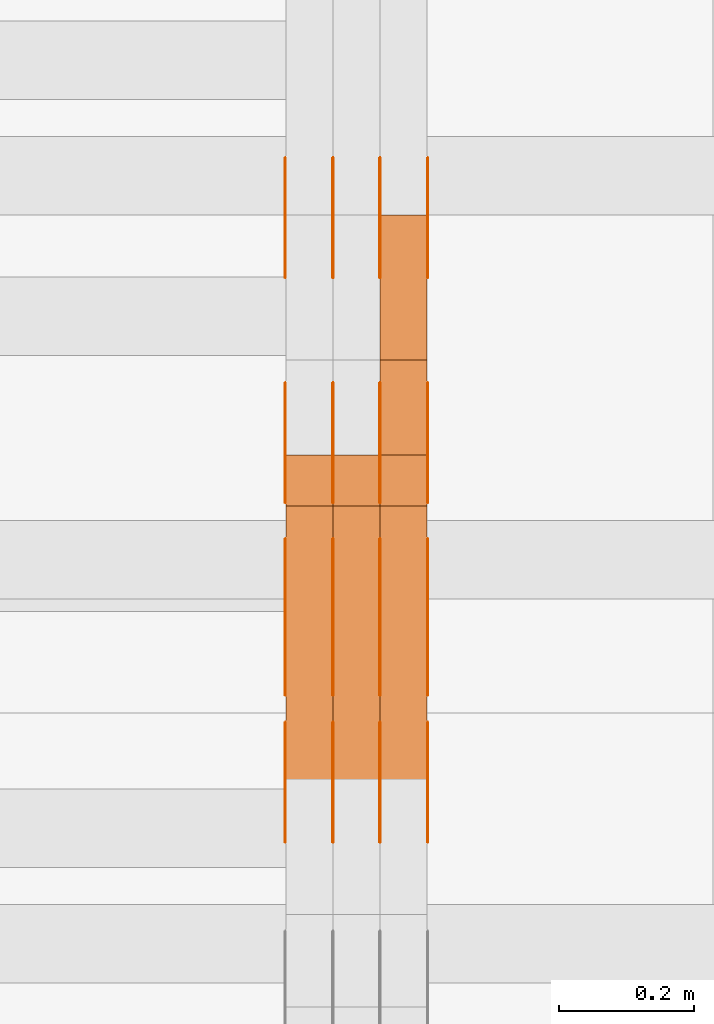
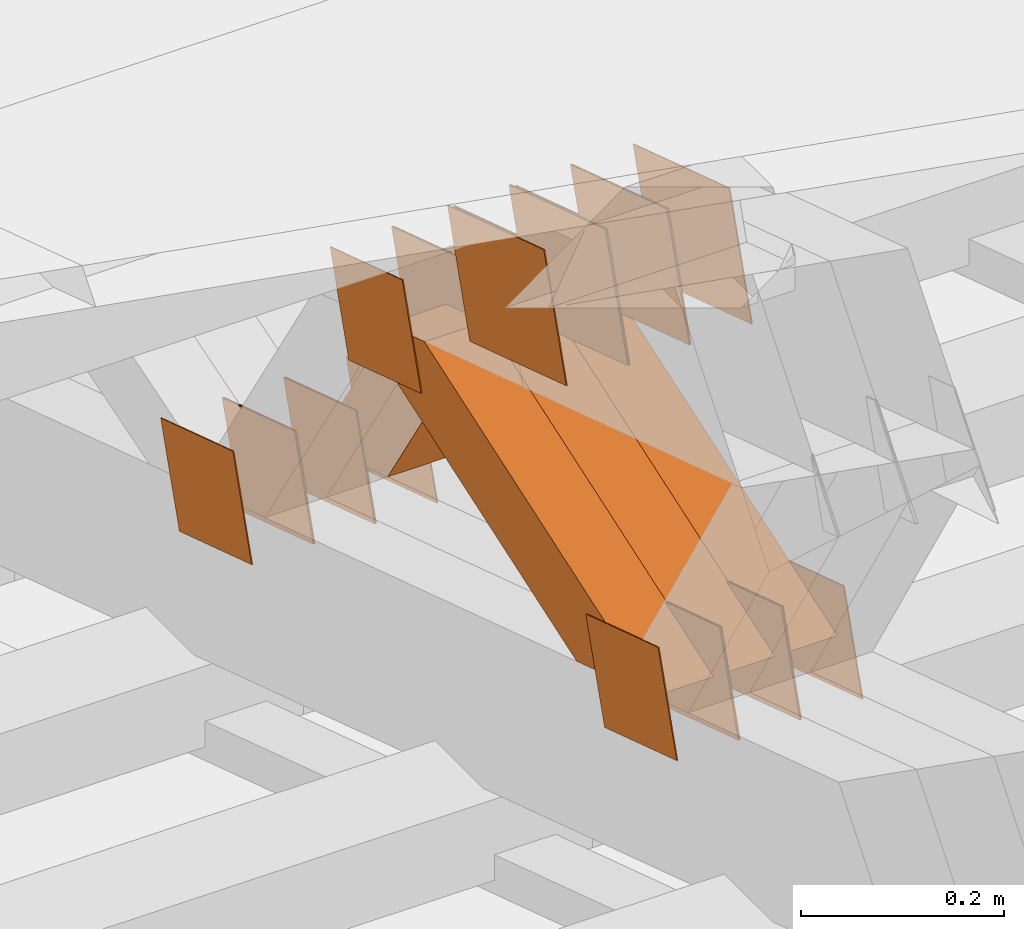
# One storey, part 173 of 385: 28 proxies.
"""IFC2X3 building model written with IfcOpenShell, lengths in millimetres."""

from ifc_helpers import new_model, entity, si_unit, converted_unit, derived_unit, direction, frame, origin, place, context, subcontext, project, spatial, polyline, outline, extrude, source, transform, mapped, material, type_object, type_shapes, element, save


model = new_model("IFC2X3")

# Units and contexts
model_context = context("Model", 3, precision=0.01, world=origin(), true_north=direction((6.12303176911189e-17, 1.0)))
body_context = subcontext(model_context, "Body", "Model", "MODEL_VIEW")
ifc_project = project(units=[si_unit("LENGTHUNIT", "METRE", prefix="MILLI"), si_unit("AREAUNIT", "SQUARE_METRE"), si_unit("VOLUMEUNIT", "CUBIC_METRE"), converted_unit("PLANEANGLEUNIT", "DEGREE", entity("IfcRatioMeasure", 0.0174532925199433), si_unit("PLANEANGLEUNIT", "RADIAN"), dimensions=[0, 0, 0, 0, 0, 0, 0]), si_unit("MASSUNIT", "GRAM", prefix="KILO"), derived_unit("MASSDENSITYUNIT", [(si_unit("MASSUNIT", "GRAM", prefix="KILO"), 1), (si_unit("LENGTHUNIT", "METRE"), -3)]), si_unit("TIMEUNIT", "SECOND"), si_unit("FREQUENCYUNIT", "HERTZ"), si_unit("THERMODYNAMICTEMPERATUREUNIT", "DEGREE_CELSIUS"), derived_unit("THERMALTRANSMITTANCEUNIT", [(si_unit("MASSUNIT", "GRAM", prefix="KILO"), 1), (si_unit("THERMODYNAMICTEMPERATUREUNIT", "KELVIN"), -1), (si_unit("TIMEUNIT", "SECOND"), -3)]), derived_unit("VOLUMETRICFLOWRATEUNIT", [(si_unit("LENGTHUNIT", "METRE"), 3), (si_unit("TIMEUNIT", "SECOND"), -1)]), si_unit("ELECTRICCURRENTUNIT", "AMPERE"), si_unit("ELECTRICVOLTAGEUNIT", "VOLT"), si_unit("POWERUNIT", "WATT"), si_unit("FORCEUNIT", "NEWTON", prefix="KILO"), si_unit("ILLUMINANCEUNIT", "LUX"), si_unit("LUMINOUSFLUXUNIT", "LUMEN"), si_unit("LUMINOUSINTENSITYUNIT", "CANDELA"), derived_unit("USERDEFINED", [(si_unit("MASSUNIT", "GRAM", prefix="KILO"), -1), (si_unit("LENGTHUNIT", "METRE"), -2), (si_unit("TIMEUNIT", "SECOND"), 3), (si_unit("LUMINOUSFLUXUNIT", "LUMEN"), 1)]), derived_unit("LINEARVELOCITYUNIT", [(si_unit("LENGTHUNIT", "METRE"), 1), (si_unit("TIMEUNIT", "SECOND"), -1)]), si_unit("PRESSUREUNIT", "PASCAL"), derived_unit("USERDEFINED", [(si_unit("LENGTHUNIT", "METRE"), -2), (si_unit("MASSUNIT", "GRAM", prefix="KILO"), 1), (si_unit("TIMEUNIT", "SECOND"), -2)])], contexts=[model_context])

# Site, building, storey
site_placement = place(None, origin())
site = spatial("IfcSite", under=ifc_project, at=site_placement, CompositionType="ELEMENT")
building_placement = place(site_placement, origin())
building = spatial("IfcBuilding", under=site, at=building_placement, CompositionType="ELEMENT")
storey_placement = place(building_placement, origin())
storey = spatial("IfcBuildingStorey", under=building, at=storey_placement, Name="Default", CompositionType="ELEMENT", Elevation=0.0)

# Proxies
ifc_material_1 = material(Name="IfcSurfaceStyle #74490")
building_element_proxy_type_1 = type_object("IfcBuildingElementProxyType", PredefinedType="NOTDEFINED", material=ifc_material_1)
shared_shape_1 = source(origin(), body_context, "Body", "SweptSolid", [
    extrude(outline(polyline([(-74.9998605591059, -59.9999264677526), (74.999875428623, -59.9999264677526), (74.9998605591068, 59.9999264677526), (-74.9998754286239, 59.9999264677526), (-74.9998605591059, -59.9999264677526)])), frame((75.0000889884782, 60.0000460315623, 0.0), z_axis=(0.0, 0.0, 1.0), x_axis=(-1.0, 0.0, 0.0)), (0.0, 0.0, 1.0), 1.3),
])
type_shapes(building_element_proxy_type_1, [shared_shape_1])
proxy_1_placement = place(building_placement, frame((3386.29999999999, 20621.9679769682, 2241.76551219004), z_axis=(-1.0, 0.0, 0.0), x_axis=(0.0, -0.951056516295154, 0.309016994374948)))
element("IfcBuildingElementProxy", 1, at=proxy_1_placement, inside=storey, type_object=building_element_proxy_type_1, material=ifc_material_1, context=body_context, shape_type="MappedRepresentation", body=[
    mapped(shared_shape_1, transform((0.0, 0.0, 0.0), scale=1.0)),
])
ifc_material_2 = material(Name="IfcSurfaceStyle #74433")
building_element_proxy_type_2 = type_object("IfcBuildingElementProxyType", PredefinedType="NOTDEFINED", material=ifc_material_2)
shared_shape_2 = source(origin(), body_context, "Body", "SweptSolid", [
    extrude(outline(polyline([(-74.9998605591059, -59.9999264677526), (74.999875428623, -59.9999264677526), (74.9998605591068, 59.9999264677526), (-74.9998754286239, 59.9999264677526), (-74.9998605591059, -59.9999264677526)])), frame((75.0000889884782, 60.0000460315623, 0.0), z_axis=(0.0, 0.0, 1.0), x_axis=(-1.0, 0.0, 0.0)), (0.0, 0.0, 1.0), 1.3),
])
type_shapes(building_element_proxy_type_2, [shared_shape_2])
proxy_2_placement = place(building_placement, frame((3315.0, 20621.9679769682, 2241.76551219004), z_axis=(-1.0, 0.0, 0.0), x_axis=(0.0, -0.951056516295154, 0.309016994374948)))
element("IfcBuildingElementProxy", 2, at=proxy_2_placement, inside=storey, type_object=building_element_proxy_type_2, material=ifc_material_2, context=body_context, shape_type="MappedRepresentation", body=[
    mapped(shared_shape_2, transform((0.0, 0.0, 0.0), scale=1.0)),
])
ifc_material_3 = material(Name="IfcSurfaceStyle #74376")
building_element_proxy_type_3 = type_object("IfcBuildingElementProxyType", PredefinedType="NOTDEFINED", material=ifc_material_3)
shared_shape_3 = source(origin(), body_context, "Body", "SweptSolid", [
    extrude(outline(polyline([(-74.9998605591059, -59.9999264677526), (74.999875428623, -59.9999264677526), (74.9998605591068, 59.9999264677526), (-74.9998754286239, 59.9999264677526), (-74.9998605591059, -59.9999264677526)])), frame((75.0000889884782, 60.0000460315623, 0.0), z_axis=(0.0, 0.0, 1.0), x_axis=(-1.0, 0.0, 0.0)), (0.0, 0.0, 1.0), 1.3),
])
type_shapes(building_element_proxy_type_3, [shared_shape_3])
proxy_3_placement = place(building_placement, frame((3316.29999999999, 20621.9679769682, 2241.76551219004), z_axis=(-1.0, 0.0, 0.0), x_axis=(0.0, -0.951056516295154, 0.309016994374948)))
element("IfcBuildingElementProxy", 3, at=proxy_3_placement, inside=storey, type_object=building_element_proxy_type_3, material=ifc_material_3, context=body_context, shape_type="MappedRepresentation", body=[
    mapped(shared_shape_3, transform((0.0, 0.0, 0.0), scale=1.0)),
])
ifc_material_4 = material(Name="IfcSurfaceStyle #74319")
building_element_proxy_type_4 = type_object("IfcBuildingElementProxyType", PredefinedType="NOTDEFINED", material=ifc_material_4)
shared_shape_4 = source(origin(), body_context, "Body", "SweptSolid", [
    extrude(outline(polyline([(-74.9998605591059, -59.9999264677526), (74.999875428623, -59.9999264677526), (74.9998605591068, 59.9999264677526), (-74.9998754286239, 59.9999264677526), (-74.9998605591059, -59.9999264677526)])), frame((75.0000889884782, 60.0000460315623, 0.0), z_axis=(0.0, 0.0, 1.0), x_axis=(-1.0, 0.0, 0.0)), (0.0, 0.0, 1.0), 1.29999999999999),
])
type_shapes(building_element_proxy_type_4, [shared_shape_4])
proxy_4_placement = place(building_placement, frame((3245.0, 20621.9679769682, 2241.76551219004), z_axis=(-1.0, 0.0, 0.0), x_axis=(0.0, -0.951056516295154, 0.309016994374948)))
element("IfcBuildingElementProxy", 4, at=proxy_4_placement, inside=storey, type_object=building_element_proxy_type_4, material=ifc_material_4, context=body_context, shape_type="MappedRepresentation", body=[
    mapped(shared_shape_4, transform((0.0, 0.0, 0.0), scale=1.0)),
])
ifc_material_5 = material(Name="IfcSurfaceStyle #74262")
building_element_proxy_type_5 = type_object("IfcBuildingElementProxyType", PredefinedType="NOTDEFINED", material=ifc_material_5)
shared_shape_5 = source(origin(), body_context, "Body", "SweptSolid", [
    extrude(outline(polyline([(-74.9998605591059, -59.9999264677526), (74.999875428623, -59.9999264677526), (74.9998605591068, 59.9999264677526), (-74.9998754286239, 59.9999264677526), (-74.9998605591059, -59.9999264677526)])), frame((75.0000889884782, 60.0000460315623, 0.0), z_axis=(0.0, 0.0, 1.0), x_axis=(-1.0, 0.0, 0.0)), (0.0, 0.0, 1.0), 1.29999999999999),
])
type_shapes(building_element_proxy_type_5, [shared_shape_5])
proxy_5_placement = place(building_placement, frame((3246.29999999999, 20621.9679769682, 2241.76551219004), z_axis=(-1.0, 0.0, 0.0), x_axis=(0.0, -0.951056516295154, 0.309016994374948)))
element("IfcBuildingElementProxy", 5, at=proxy_5_placement, inside=storey, type_object=building_element_proxy_type_5, material=ifc_material_5, context=body_context, shape_type="MappedRepresentation", body=[
    mapped(shared_shape_5, transform((0.0, 0.0, 0.0), scale=1.0)),
])
ifc_material_6 = material(Name="IfcSurfaceStyle #74205")
building_element_proxy_type_6 = type_object("IfcBuildingElementProxyType", PredefinedType="NOTDEFINED", material=ifc_material_6)
shared_shape_6 = source(origin(), body_context, "Body", "SweptSolid", [
    extrude(outline(polyline([(-74.9998605591059, -59.9999264677526), (74.999875428623, -59.9999264677526), (74.9998605591068, 59.9999264677526), (-74.9998754286239, 59.9999264677526), (-74.9998605591059, -59.9999264677526)])), frame((75.0000889884782, 60.0000460315623, 0.0), z_axis=(0.0, 0.0, 1.0), x_axis=(-1.0, 0.0, 0.0)), (0.0, 0.0, 1.0), 1.29999999999999),
])
type_shapes(building_element_proxy_type_6, [shared_shape_6])
proxy_6_placement = place(building_placement, frame((3175.0, 20621.9679769682, 2241.76551219004), z_axis=(-1.0, 0.0, 0.0), x_axis=(0.0, -0.951056516295154, 0.309016994374948)))
element("IfcBuildingElementProxy", 6, at=proxy_6_placement, inside=storey, type_object=building_element_proxy_type_6, material=ifc_material_6, context=body_context, shape_type="MappedRepresentation", body=[
    mapped(shared_shape_6, transform((0.0, 0.0, 0.0), scale=1.0)),
])
ifc_material_7 = material(Name="IfcSurfaceStyle #72780")
building_element_proxy_type_7 = type_object("IfcBuildingElementProxyType", PredefinedType="NOTDEFINED", material=ifc_material_7)
shared_shape_7 = source(origin(), body_context, "Body", "SweptSolid", [
    extrude(outline(polyline([(-100.000260677523, -72.0000050220369), (100.000341220114, -72.0000050220369), (99.9997962944585, 72.0000050220369), (-99.9998768370492, 72.0000050220369), (-100.000260677523, -72.0000050220369)])), frame((100.000341220114, 72.0001826453454, 0.0), z_axis=(0.0, 0.0, 1.0), x_axis=(-1.0, 0.0, 0.0)), (0.0, 0.0, 1.0), 1.3),
])
type_shapes(building_element_proxy_type_7, [shared_shape_7])
proxy_7_placement = place(building_placement, frame((3386.29999999999, 20382.8706354426, 2409.35285895246), z_axis=(-1.0, 0.0, 0.0), x_axis=(0.0, -0.951056516295154, 0.309016994374948)))
element("IfcBuildingElementProxy", 7, at=proxy_7_placement, inside=storey, type_object=building_element_proxy_type_7, material=ifc_material_7, context=body_context, shape_type="MappedRepresentation", body=[
    mapped(shared_shape_7, transform((0.0, 0.0, 0.0), scale=1.0)),
])
ifc_material_8 = material(Name="IfcSurfaceStyle #72723")
building_element_proxy_type_8 = type_object("IfcBuildingElementProxyType", PredefinedType="NOTDEFINED", material=ifc_material_8)
shared_shape_8 = source(origin(), body_context, "Body", "SweptSolid", [
    extrude(outline(polyline([(-100.000260677523, -72.0000050220369), (100.000341220114, -72.0000050220369), (99.9997962944585, 72.0000050220369), (-99.9998768370492, 72.0000050220369), (-100.000260677523, -72.0000050220369)])), frame((100.000341220114, 72.0001826453454, 0.0), z_axis=(0.0, 0.0, 1.0), x_axis=(-1.0, 0.0, 0.0)), (0.0, 0.0, 1.0), 1.3),
])
type_shapes(building_element_proxy_type_8, [shared_shape_8])
proxy_8_placement = place(building_placement, frame((3315.0, 20382.8706354426, 2409.35285895246), z_axis=(-1.0, 0.0, 0.0), x_axis=(0.0, -0.951056516295154, 0.309016994374948)))
element("IfcBuildingElementProxy", 8, at=proxy_8_placement, inside=storey, type_object=building_element_proxy_type_8, material=ifc_material_8, context=body_context, shape_type="MappedRepresentation", body=[
    mapped(shared_shape_8, transform((0.0, 0.0, 0.0), scale=1.0)),
])
ifc_material_9 = material(Name="IfcSurfaceStyle #72666")
building_element_proxy_type_9 = type_object("IfcBuildingElementProxyType", PredefinedType="NOTDEFINED", material=ifc_material_9)
shared_shape_9 = source(origin(), body_context, "Body", "SweptSolid", [
    extrude(outline(polyline([(-100.000260677523, -72.0000050220369), (100.000341220114, -72.0000050220369), (99.9997962944585, 72.0000050220369), (-99.9998768370492, 72.0000050220369), (-100.000260677523, -72.0000050220369)])), frame((100.000341220114, 72.0001826453454, 0.0), z_axis=(0.0, 0.0, 1.0), x_axis=(-1.0, 0.0, 0.0)), (0.0, 0.0, 1.0), 1.3),
])
type_shapes(building_element_proxy_type_9, [shared_shape_9])
proxy_9_placement = place(building_placement, frame((3316.29999999999, 20382.8706354426, 2409.35285895246), z_axis=(-1.0, 0.0, 0.0), x_axis=(0.0, -0.951056516295154, 0.309016994374948)))
element("IfcBuildingElementProxy", 9, at=proxy_9_placement, inside=storey, type_object=building_element_proxy_type_9, material=ifc_material_9, context=body_context, shape_type="MappedRepresentation", body=[
    mapped(shared_shape_9, transform((0.0, 0.0, 0.0), scale=1.0)),
])
ifc_material_10 = material(Name="IfcSurfaceStyle #72609")
building_element_proxy_type_10 = type_object("IfcBuildingElementProxyType", PredefinedType="NOTDEFINED", material=ifc_material_10)
shared_shape_10 = source(origin(), body_context, "Body", "SweptSolid", [
    extrude(outline(polyline([(-100.000260677523, -72.0000050220369), (100.000341220114, -72.0000050220369), (99.9997962944585, 72.0000050220369), (-99.9998768370492, 72.0000050220369), (-100.000260677523, -72.0000050220369)])), frame((100.000341220114, 72.0001826453454, 0.0), z_axis=(0.0, 0.0, 1.0), x_axis=(-1.0, 0.0, 0.0)), (0.0, 0.0, 1.0), 1.29999999999998),
])
type_shapes(building_element_proxy_type_10, [shared_shape_10])
proxy_10_placement = place(building_placement, frame((3245.0, 20382.8706354426, 2409.35285895246), z_axis=(-1.0, 0.0, 0.0), x_axis=(0.0, -0.951056516295154, 0.309016994374948)))
element("IfcBuildingElementProxy", 10, at=proxy_10_placement, inside=storey, type_object=building_element_proxy_type_10, material=ifc_material_10, context=body_context, shape_type="MappedRepresentation", body=[
    mapped(shared_shape_10, transform((0.0, 0.0, 0.0), scale=1.0)),
])
ifc_material_11 = material(Name="IfcSurfaceStyle #72552")
building_element_proxy_type_11 = type_object("IfcBuildingElementProxyType", PredefinedType="NOTDEFINED", material=ifc_material_11)
shared_shape_11 = source(origin(), body_context, "Body", "SweptSolid", [
    extrude(outline(polyline([(-100.000260677523, -72.0000050220369), (100.000341220114, -72.0000050220369), (99.9997962944585, 72.0000050220369), (-99.9998768370492, 72.0000050220369), (-100.000260677523, -72.0000050220369)])), frame((100.000341220114, 72.0001826453454, 0.0), z_axis=(0.0, 0.0, 1.0), x_axis=(-1.0, 0.0, 0.0)), (0.0, 0.0, 1.0), 1.29999999999998),
])
type_shapes(building_element_proxy_type_11, [shared_shape_11])
proxy_11_placement = place(building_placement, frame((3246.29999999999, 20382.8706354426, 2409.35285895246), z_axis=(-1.0, 0.0, 0.0), x_axis=(0.0, -0.951056516295154, 0.309016994374948)))
element("IfcBuildingElementProxy", 11, at=proxy_11_placement, inside=storey, type_object=building_element_proxy_type_11, material=ifc_material_11, context=body_context, shape_type="MappedRepresentation", body=[
    mapped(shared_shape_11, transform((0.0, 0.0, 0.0), scale=1.0)),
])
ifc_material_12 = material(Name="IfcSurfaceStyle #72495")
building_element_proxy_type_12 = type_object("IfcBuildingElementProxyType", PredefinedType="NOTDEFINED", material=ifc_material_12)
shared_shape_12 = source(origin(), body_context, "Body", "SweptSolid", [
    extrude(outline(polyline([(-100.000260677523, -72.0000050220369), (100.000341220114, -72.0000050220369), (99.9997962944585, 72.0000050220369), (-99.9998768370492, 72.0000050220369), (-100.000260677523, -72.0000050220369)])), frame((100.000341220114, 72.0001826453454, 0.0), z_axis=(0.0, 0.0, 1.0), x_axis=(-1.0, 0.0, 0.0)), (0.0, 0.0, 1.0), 1.29999999999999),
])
type_shapes(building_element_proxy_type_12, [shared_shape_12])
proxy_12_placement = place(building_placement, frame((3175.0, 20382.8706354426, 2409.35285895246), z_axis=(-1.0, 0.0, 0.0), x_axis=(0.0, -0.951056516295154, 0.309016994374948)))
element("IfcBuildingElementProxy", 12, at=proxy_12_placement, inside=storey, type_object=building_element_proxy_type_12, material=ifc_material_12, context=body_context, shape_type="MappedRepresentation", body=[
    mapped(shared_shape_12, transform((0.0, 0.0, 0.0), scale=1.0)),
])
ifc_material_13 = material(Name="IfcSurfaceStyle #66282")
building_element_proxy_type_13 = type_object("IfcBuildingElementProxyType", PredefinedType="NOTDEFINED", material=ifc_material_13)
shared_shape_13 = source(origin(), body_context, "Body", "SweptSolid", [
    extrude(outline(polyline([(-74.9998605591118, -59.9999264677598), (74.9998754286171, -59.9999264677598), (74.9998605591136, 59.9999264677598), (-74.9998754286189, 59.9999264677598), (-74.9998605591118, -59.9999264677598)])), frame((75.0000347664736, 60.0000016373434, 0.0), z_axis=(0.0, 0.0, 1.0), x_axis=(-1.0, 0.0, 0.0)), (0.0, 0.0, 1.0), 1.3),
])
type_shapes(building_element_proxy_type_13, [shared_shape_13])
proxy_13_placement = place(building_placement, frame((3386.29999999999, 20117.0890328685, 2105.40814929196), z_axis=(-1.0, 0.0, 0.0), x_axis=(0.0, -0.951056516295124, 0.309016994375039)))
element("IfcBuildingElementProxy", 13, at=proxy_13_placement, inside=storey, type_object=building_element_proxy_type_13, material=ifc_material_13, context=body_context, shape_type="MappedRepresentation", body=[
    mapped(shared_shape_13, transform((0.0, 0.0, 0.0), scale=1.0)),
])
ifc_material_14 = material(Name="IfcSurfaceStyle #66225")
building_element_proxy_type_14 = type_object("IfcBuildingElementProxyType", PredefinedType="NOTDEFINED", material=ifc_material_14)
shared_shape_14 = source(origin(), body_context, "Body", "SweptSolid", [
    extrude(outline(polyline([(-74.9998605591118, -59.9999264677598), (74.9998754286171, -59.9999264677598), (74.9998605591136, 59.9999264677598), (-74.9998754286189, 59.9999264677598), (-74.9998605591118, -59.9999264677598)])), frame((75.0000347664736, 60.0000016373434, 0.0), z_axis=(0.0, 0.0, 1.0), x_axis=(-1.0, 0.0, 0.0)), (0.0, 0.0, 1.0), 1.3),
])
type_shapes(building_element_proxy_type_14, [shared_shape_14])
proxy_14_placement = place(building_placement, frame((3315.0, 20117.0890328685, 2105.40814929196), z_axis=(-1.0, 0.0, 0.0), x_axis=(0.0, -0.951056516295124, 0.309016994375039)))
element("IfcBuildingElementProxy", 14, at=proxy_14_placement, inside=storey, type_object=building_element_proxy_type_14, material=ifc_material_14, context=body_context, shape_type="MappedRepresentation", body=[
    mapped(shared_shape_14, transform((0.0, 0.0, 0.0), scale=1.0)),
])
ifc_material_15 = material(Name="IfcSurfaceStyle #66168")
building_element_proxy_type_15 = type_object("IfcBuildingElementProxyType", PredefinedType="NOTDEFINED", material=ifc_material_15)
shared_shape_15 = source(origin(), body_context, "Body", "SweptSolid", [
    extrude(outline(polyline([(-74.9998605591118, -59.9999264677598), (74.9998754286171, -59.9999264677598), (74.9998605591136, 59.9999264677598), (-74.9998754286189, 59.9999264677598), (-74.9998605591118, -59.9999264677598)])), frame((75.0000347664736, 60.0000016373434, 0.0), z_axis=(0.0, 0.0, 1.0), x_axis=(-1.0, 0.0, 0.0)), (0.0, 0.0, 1.0), 1.3),
])
type_shapes(building_element_proxy_type_15, [shared_shape_15])
proxy_15_placement = place(building_placement, frame((3316.29999999999, 20117.0890328685, 2105.40814929196), z_axis=(-1.0, 0.0, 0.0), x_axis=(0.0, -0.951056516295124, 0.309016994375039)))
element("IfcBuildingElementProxy", 15, at=proxy_15_placement, inside=storey, type_object=building_element_proxy_type_15, material=ifc_material_15, context=body_context, shape_type="MappedRepresentation", body=[
    mapped(shared_shape_15, transform((0.0, 0.0, 0.0), scale=1.0)),
])
ifc_material_16 = material(Name="IfcSurfaceStyle #66111")
building_element_proxy_type_16 = type_object("IfcBuildingElementProxyType", PredefinedType="NOTDEFINED", material=ifc_material_16)
shared_shape_16 = source(origin(), body_context, "Body", "SweptSolid", [
    extrude(outline(polyline([(-74.9998605591118, -59.9999264677598), (74.9998754286171, -59.9999264677598), (74.9998605591136, 59.9999264677598), (-74.9998754286189, 59.9999264677598), (-74.9998605591118, -59.9999264677598)])), frame((75.0000347664736, 60.0000016373434, 0.0), z_axis=(0.0, 0.0, 1.0), x_axis=(-1.0, 0.0, 0.0)), (0.0, 0.0, 1.0), 1.29999999999999),
])
type_shapes(building_element_proxy_type_16, [shared_shape_16])
proxy_16_placement = place(building_placement, frame((3245.0, 20117.0890328685, 2105.40814929196), z_axis=(-1.0, 0.0, 0.0), x_axis=(0.0, -0.951056516295124, 0.309016994375039)))
element("IfcBuildingElementProxy", 16, at=proxy_16_placement, inside=storey, type_object=building_element_proxy_type_16, material=ifc_material_16, context=body_context, shape_type="MappedRepresentation", body=[
    mapped(shared_shape_16, transform((0.0, 0.0, 0.0), scale=1.0)),
])
ifc_material_17 = material(Name="IfcSurfaceStyle #66054")
building_element_proxy_type_17 = type_object("IfcBuildingElementProxyType", PredefinedType="NOTDEFINED", material=ifc_material_17)
shared_shape_17 = source(origin(), body_context, "Body", "SweptSolid", [
    extrude(outline(polyline([(-74.9998605591118, -59.9999264677598), (74.9998754286171, -59.9999264677598), (74.9998605591136, 59.9999264677598), (-74.9998754286189, 59.9999264677598), (-74.9998605591118, -59.9999264677598)])), frame((75.0000347664736, 60.0000016373434, 0.0), z_axis=(0.0, 0.0, 1.0), x_axis=(-1.0, 0.0, 0.0)), (0.0, 0.0, 1.0), 1.29999999999999),
])
type_shapes(building_element_proxy_type_17, [shared_shape_17])
proxy_17_placement = place(building_placement, frame((3246.29999999999, 20117.0890328685, 2105.40814929196), z_axis=(-1.0, 0.0, 0.0), x_axis=(0.0, -0.951056516295124, 0.309016994375039)))
element("IfcBuildingElementProxy", 17, at=proxy_17_placement, inside=storey, type_object=building_element_proxy_type_17, material=ifc_material_17, context=body_context, shape_type="MappedRepresentation", body=[
    mapped(shared_shape_17, transform((0.0, 0.0, 0.0), scale=1.0)),
])
ifc_material_18 = material(Name="IfcSurfaceStyle #65997")
building_element_proxy_type_18 = type_object("IfcBuildingElementProxyType", PredefinedType="NOTDEFINED", material=ifc_material_18)
shared_shape_18 = source(origin(), body_context, "Body", "SweptSolid", [
    extrude(outline(polyline([(-74.9998605591118, -59.9999264677598), (74.9998754286171, -59.9999264677598), (74.9998605591136, 59.9999264677598), (-74.9998754286189, 59.9999264677598), (-74.9998605591118, -59.9999264677598)])), frame((75.0000347664736, 60.0000016373434, 0.0), z_axis=(0.0, 0.0, 1.0), x_axis=(-1.0, 0.0, 0.0)), (0.0, 0.0, 1.0), 1.29999999999999),
])
type_shapes(building_element_proxy_type_18, [shared_shape_18])
proxy_18_placement = place(building_placement, frame((3175.0, 20117.0890328685, 2105.40814929196), z_axis=(-1.0, 0.0, 0.0), x_axis=(0.0, -0.951056516295124, 0.309016994375039)))
element("IfcBuildingElementProxy", 18, at=proxy_18_placement, inside=storey, type_object=building_element_proxy_type_18, material=ifc_material_18, context=body_context, shape_type="MappedRepresentation", body=[
    mapped(shared_shape_18, transform((0.0, 0.0, 0.0), scale=1.0)),
])
ifc_material_19 = material(Name="IfcSurfaceStyle #65940")
building_element_proxy_type_19 = type_object("IfcBuildingElementProxyType", PredefinedType="NOTDEFINED", material=ifc_material_19)
shared_shape_19 = source(origin(), body_context, "Body", "SweptSolid", [
    extrude(outline(polyline([(-74.9998794200132, -59.999984515643), (74.9998565677174, -59.999984515643), (74.9998794200123, 59.999984515643), (-74.9998565677165, 59.999984515643), (-74.9998794200132, -59.999984515643)])), frame((75.0002235343086, 60.0000596852268, 0.0), z_axis=(0.0, 0.0, 1.0), x_axis=(-1.0, 0.0, 0.0)), (0.0, 0.0, 1.0), 1.3),
])
type_shapes(building_element_proxy_type_19, [shared_shape_19])
proxy_19_placement = place(building_placement, frame((3386.29999999999, 20956.2317725846, 1832.75404405346), z_axis=(-1.0, 0.0, 0.0), x_axis=(0.0, -0.951056516295124, 0.309016994375039)))
element("IfcBuildingElementProxy", 19, at=proxy_19_placement, inside=storey, type_object=building_element_proxy_type_19, material=ifc_material_19, context=body_context, shape_type="MappedRepresentation", body=[
    mapped(shared_shape_19, transform((0.0, 0.0, 0.0), scale=1.0)),
])
ifc_material_20 = material(Name="IfcSurfaceStyle #65883")
building_element_proxy_type_20 = type_object("IfcBuildingElementProxyType", PredefinedType="NOTDEFINED", material=ifc_material_20)
shared_shape_20 = source(origin(), body_context, "Body", "SweptSolid", [
    extrude(outline(polyline([(-74.9998794200132, -59.999984515643), (74.9998565677174, -59.999984515643), (74.9998794200123, 59.999984515643), (-74.9998565677165, 59.999984515643), (-74.9998794200132, -59.999984515643)])), frame((75.0002235343086, 60.0000596852268, 0.0), z_axis=(0.0, 0.0, 1.0), x_axis=(-1.0, 0.0, 0.0)), (0.0, 0.0, 1.0), 1.3),
])
type_shapes(building_element_proxy_type_20, [shared_shape_20])
proxy_20_placement = place(building_placement, frame((3315.0, 20956.2317725846, 1832.75404405346), z_axis=(-1.0, 0.0, 0.0), x_axis=(0.0, -0.951056516295124, 0.309016994375039)))
element("IfcBuildingElementProxy", 20, at=proxy_20_placement, inside=storey, type_object=building_element_proxy_type_20, material=ifc_material_20, context=body_context, shape_type="MappedRepresentation", body=[
    mapped(shared_shape_20, transform((0.0, 0.0, 0.0), scale=1.0)),
])
ifc_material_21 = material(Name="IfcSurfaceStyle #65826")
building_element_proxy_type_21 = type_object("IfcBuildingElementProxyType", PredefinedType="NOTDEFINED", material=ifc_material_21)
shared_shape_21 = source(origin(), body_context, "Body", "SweptSolid", [
    extrude(outline(polyline([(-74.9998794200132, -59.999984515643), (74.9998565677174, -59.999984515643), (74.9998794200123, 59.999984515643), (-74.9998565677165, 59.999984515643), (-74.9998794200132, -59.999984515643)])), frame((75.0002235343086, 60.0000596852268, 0.0), z_axis=(0.0, 0.0, 1.0), x_axis=(-1.0, 0.0, 0.0)), (0.0, 0.0, 1.0), 1.3),
])
type_shapes(building_element_proxy_type_21, [shared_shape_21])
proxy_21_placement = place(building_placement, frame((3316.29999999999, 20956.2317725846, 1832.75404405346), z_axis=(-1.0, 0.0, 0.0), x_axis=(0.0, -0.951056516295124, 0.309016994375039)))
element("IfcBuildingElementProxy", 21, at=proxy_21_placement, inside=storey, type_object=building_element_proxy_type_21, material=ifc_material_21, context=body_context, shape_type="MappedRepresentation", body=[
    mapped(shared_shape_21, transform((0.0, 0.0, 0.0), scale=1.0)),
])
ifc_material_22 = material(Name="IfcSurfaceStyle #65769")
building_element_proxy_type_22 = type_object("IfcBuildingElementProxyType", PredefinedType="NOTDEFINED", material=ifc_material_22)
shared_shape_22 = source(origin(), body_context, "Body", "SweptSolid", [
    extrude(outline(polyline([(-74.9998794200132, -59.999984515643), (74.9998565677174, -59.999984515643), (74.9998794200123, 59.999984515643), (-74.9998565677165, 59.999984515643), (-74.9998794200132, -59.999984515643)])), frame((75.0002235343086, 60.0000596852268, 0.0), z_axis=(0.0, 0.0, 1.0), x_axis=(-1.0, 0.0, 0.0)), (0.0, 0.0, 1.0), 1.29999999999999),
])
type_shapes(building_element_proxy_type_22, [shared_shape_22])
proxy_22_placement = place(building_placement, frame((3245.0, 20956.2317725846, 1832.75404405346), z_axis=(-1.0, 0.0, 0.0), x_axis=(0.0, -0.951056516295124, 0.309016994375039)))
element("IfcBuildingElementProxy", 22, at=proxy_22_placement, inside=storey, type_object=building_element_proxy_type_22, material=ifc_material_22, context=body_context, shape_type="MappedRepresentation", body=[
    mapped(shared_shape_22, transform((0.0, 0.0, 0.0), scale=1.0)),
])
ifc_material_23 = material(Name="IfcSurfaceStyle #65712")
building_element_proxy_type_23 = type_object("IfcBuildingElementProxyType", PredefinedType="NOTDEFINED", material=ifc_material_23)
shared_shape_23 = source(origin(), body_context, "Body", "SweptSolid", [
    extrude(outline(polyline([(-74.9998794200132, -59.999984515643), (74.9998565677174, -59.999984515643), (74.9998794200123, 59.999984515643), (-74.9998565677165, 59.999984515643), (-74.9998794200132, -59.999984515643)])), frame((75.0002235343086, 60.0000596852268, 0.0), z_axis=(0.0, 0.0, 1.0), x_axis=(-1.0, 0.0, 0.0)), (0.0, 0.0, 1.0), 1.29999999999999),
])
type_shapes(building_element_proxy_type_23, [shared_shape_23])
proxy_23_placement = place(building_placement, frame((3246.29999999999, 20956.2317725846, 1832.75404405346), z_axis=(-1.0, 0.0, 0.0), x_axis=(0.0, -0.951056516295124, 0.309016994375039)))
element("IfcBuildingElementProxy", 23, at=proxy_23_placement, inside=storey, type_object=building_element_proxy_type_23, material=ifc_material_23, context=body_context, shape_type="MappedRepresentation", body=[
    mapped(shared_shape_23, transform((0.0, 0.0, 0.0), scale=1.0)),
])
ifc_material_24 = material(Name="IfcSurfaceStyle #65655")
building_element_proxy_type_24 = type_object("IfcBuildingElementProxyType", PredefinedType="NOTDEFINED", material=ifc_material_24)
shared_shape_24 = source(origin(), body_context, "Body", "SweptSolid", [
    extrude(outline(polyline([(-74.9998794200132, -59.999984515643), (74.9998565677174, -59.999984515643), (74.9998794200123, 59.999984515643), (-74.9998565677165, 59.999984515643), (-74.9998794200132, -59.999984515643)])), frame((75.0002235343086, 60.0000596852268, 0.0), z_axis=(0.0, 0.0, 1.0), x_axis=(-1.0, 0.0, 0.0)), (0.0, 0.0, 1.0), 1.29999999999999),
])
type_shapes(building_element_proxy_type_24, [shared_shape_24])
proxy_24_placement = place(building_placement, frame((3175.0, 20956.2317725846, 1832.75404405346), z_axis=(-1.0, 0.0, 0.0), x_axis=(0.0, -0.951056516295124, 0.309016994375039)))
element("IfcBuildingElementProxy", 24, at=proxy_24_placement, inside=storey, type_object=building_element_proxy_type_24, material=ifc_material_24, context=body_context, shape_type="MappedRepresentation", body=[
    mapped(shared_shape_24, transform((0.0, 0.0, 0.0), scale=1.0)),
])
ifc_material_25 = material(Name="IfcSurfaceStyle #48678")
building_element_proxy_type_25 = type_object("IfcBuildingElementProxyType", Name="T1-W26 48676", PredefinedType="NOTDEFINED", material=ifc_material_25)
shared_shape_25 = source(origin(), body_context, "Body", "SweptSolid", [
    extrude(outline(polyline([(-339.390941716546, -47.5001331548025), (137.738864791781, -47.5001331548025), (201.272298560955, 6.02772073885038e-05), (212.703852542003, 47.5001030161988), (-212.324074178193, 47.5001030161988), (-339.390941716546, -47.5001331548025)])), frame((212.703852542003, 47.5001030161988, 0.0), z_axis=(0.0, 0.0, 1.0), x_axis=(-1.0, 0.0, 0.0)), (0.0, 0.0, 1.0), 70.0),
])
type_shapes(building_element_proxy_type_25, [shared_shape_25])
proxy_25_placement = place(building_placement, frame((3385.0, 20576.541015625, 2286.80981445313), z_axis=(-1.0, 0.0, 0.0), x_axis=(0.0, -0.946743816465327, -0.321987804093053)))
element("IfcBuildingElementProxy", 25, at=proxy_25_placement, inside=storey, type_object=building_element_proxy_type_25, material=ifc_material_25, Name="T1-W26", context=body_context, shape_type="MappedRepresentation", body=[
    mapped(shared_shape_25, transform((0.0, 0.0, 0.0), scale=1.0)),
])
ifc_material_26 = material(Name="IfcSurfaceStyle #48612")
building_element_proxy_type_26 = type_object("IfcBuildingElementProxyType", Name="T1-W26 48610", PredefinedType="NOTDEFINED", material=ifc_material_26)
shared_shape_26 = source(origin(), body_context, "Body", "SweptSolid", [
    extrude(outline(polyline([(-339.390941716546, -47.5001331548025), (137.738864791781, -47.5001331548025), (201.272298560955, 6.02772073885038e-05), (212.703852542003, 47.5001030161988), (-212.324074178193, 47.5001030161988), (-339.390941716546, -47.5001331548025)])), frame((212.703852542003, 47.5001030161988, 0.0), z_axis=(0.0, 0.0, 1.0), x_axis=(-1.0, 0.0, 0.0)), (0.0, 0.0, 1.0), 70.0),
])
type_shapes(building_element_proxy_type_26, [shared_shape_26])
proxy_26_placement = place(building_placement, frame((3315.0, 20576.541015625, 2286.80981445313), z_axis=(-1.0, 0.0, 0.0), x_axis=(0.0, -0.946743816465327, -0.321987804093053)))
element("IfcBuildingElementProxy", 26, at=proxy_26_placement, inside=storey, type_object=building_element_proxy_type_26, material=ifc_material_26, Name="T1-W26", context=body_context, shape_type="MappedRepresentation", body=[
    mapped(shared_shape_26, transform((0.0, 0.0, 0.0), scale=1.0)),
])
ifc_material_27 = material(Name="IfcSurfaceStyle #48546")
building_element_proxy_type_27 = type_object("IfcBuildingElementProxyType", Name="T1-W26 48544", PredefinedType="NOTDEFINED", material=ifc_material_27)
shared_shape_27 = source(origin(), body_context, "Body", "SweptSolid", [
    extrude(outline(polyline([(-339.390941716546, -47.5001331548025), (137.738864791781, -47.5001331548025), (201.272298560955, 6.02772073885038e-05), (212.703852542003, 47.5001030161988), (-212.324074178193, 47.5001030161988), (-339.390941716546, -47.5001331548025)])), frame((212.703852542003, 47.5001030161988, 0.0), z_axis=(0.0, 0.0, 1.0), x_axis=(-1.0, 0.0, 0.0)), (0.0, 0.0, 1.0), 70.0),
])
type_shapes(building_element_proxy_type_27, [shared_shape_27])
proxy_27_placement = place(building_placement, frame((3245.0, 20576.541015625, 2286.80981445313), z_axis=(-1.0, 0.0, 0.0), x_axis=(0.0, -0.946743816465327, -0.321987804093053)))
element("IfcBuildingElementProxy", 27, at=proxy_27_placement, inside=storey, type_object=building_element_proxy_type_27, material=ifc_material_27, Name="T1-W26", context=body_context, shape_type="MappedRepresentation", body=[
    mapped(shared_shape_27, transform((0.0, 0.0, 0.0), scale=1.0)),
])
ifc_material_28 = material(Name="IfcSurfaceStyle #48282")
building_element_proxy_type_28 = type_object("IfcBuildingElementProxyType", Name="T1-W29 48280", PredefinedType="NOTDEFINED", material=ifc_material_28)
shared_shape_28 = source(origin(), body_context, "Body", "SweptSolid", [
    extrude(outline(polyline([(-202.325994317059, -47.5000867467013), (200.714255560873, -47.5000867467013), (187.834128885383, 0.000593513395139059), (130.590899902046, 47.4997899900038), (-316.813290031243, 47.4997899900038), (-202.325994317059, -47.5000867467013)])), frame((200.714255560873, 47.5001935424745, 0.0), z_axis=(0.0, 0.0, 1.0), x_axis=(-1.0, 0.0, 0.0)), (0.0, 0.0, 1.0), 70.0),
])
type_shapes(building_element_proxy_type_28, [shared_shape_28])
proxy_28_placement = place(building_placement, frame((3385.0, 20827.0771193222, 1890.72342063252), z_axis=(-1.0, 0.0, 0.0), x_axis=(0.0, -0.534567451138397, 0.845125813227473)))
element("IfcBuildingElementProxy", 28, at=proxy_28_placement, inside=storey, type_object=building_element_proxy_type_28, material=ifc_material_28, Name="T1-W29", context=body_context, shape_type="MappedRepresentation", body=[
    mapped(shared_shape_28, transform((0.0, 0.0, 0.0), scale=1.0)),
])

save(model, "model.ifc")
